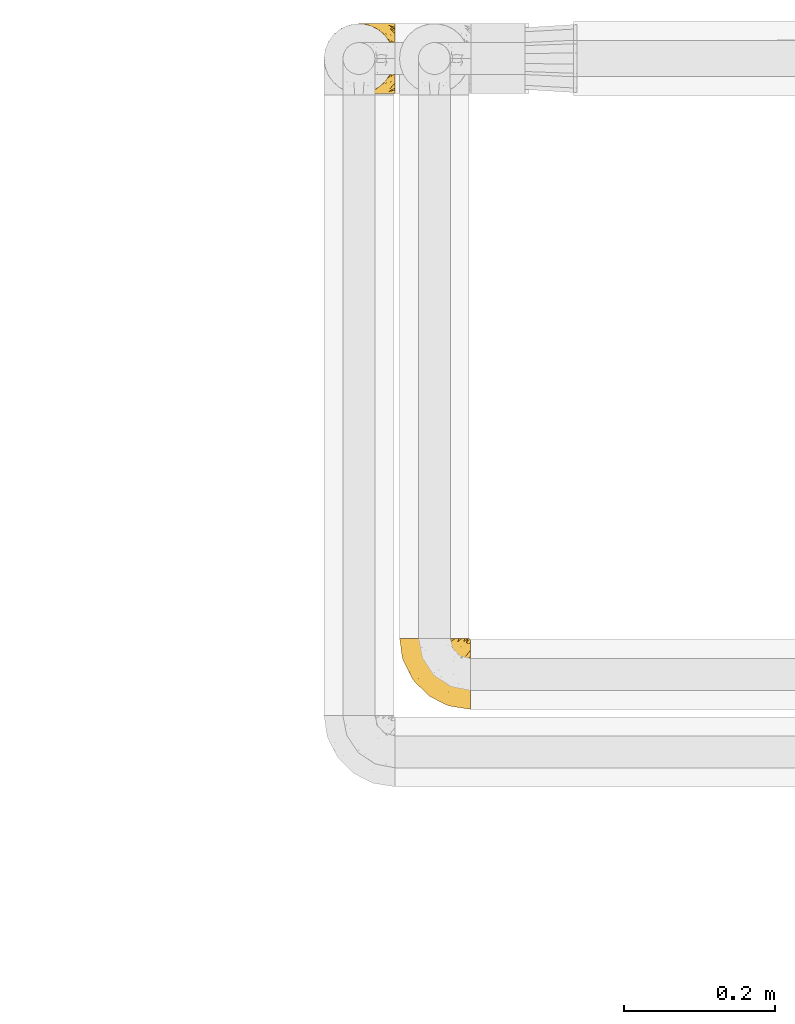
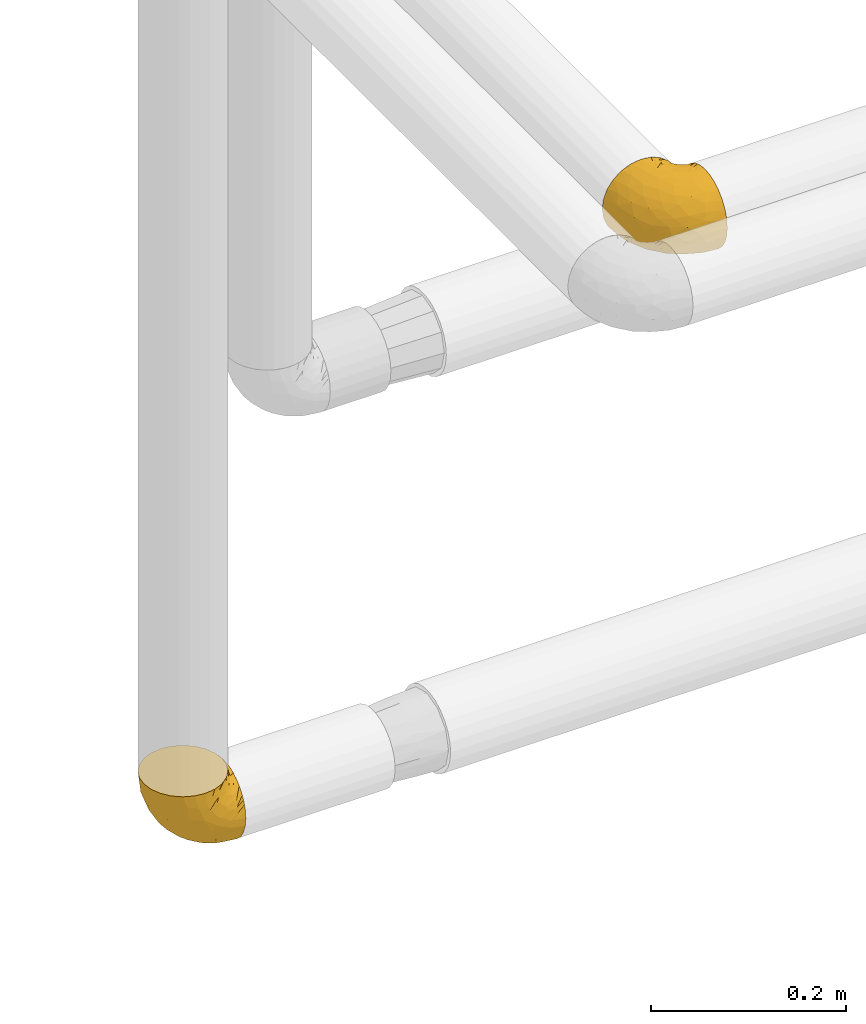
# One storey, part 305 of 827: 2 coverings.
"""IFC2X3 building model written with IfcOpenShell, lengths in millimetres."""

from ifc_helpers import new_model, entity, si_unit, converted_unit, derived_unit, direction, frame, origin, place, context, subcontext, project, spatial, faceted_brep, element, save


model = new_model("IFC2X3")

# Units and contexts
model_context = context("Model", 3, precision=0.01, world=origin(), true_north=direction((6.12303176911189e-17, 1.0)))
body_context = subcontext(model_context, "Body", "Model", "MODEL_VIEW")
ifc_project = project(units=[si_unit("LENGTHUNIT", "METRE", prefix="MILLI"), si_unit("AREAUNIT", "SQUARE_METRE"), si_unit("VOLUMEUNIT", "CUBIC_METRE"), converted_unit("PLANEANGLEUNIT", "DEGREE", entity("IfcRatioMeasure", 0.0174532925199433), si_unit("PLANEANGLEUNIT", "RADIAN"), dimensions=[0, 0, 0, 0, 0, 0, 0]), si_unit("MASSUNIT", "GRAM", prefix="KILO"), derived_unit("MASSDENSITYUNIT", [(si_unit("MASSUNIT", "GRAM", prefix="KILO"), 1), (si_unit("LENGTHUNIT", "METRE"), -3)]), derived_unit("MOMENTOFINERTIAUNIT", [(si_unit("LENGTHUNIT", "METRE"), 4)]), si_unit("TIMEUNIT", "SECOND"), si_unit("FREQUENCYUNIT", "HERTZ"), si_unit("THERMODYNAMICTEMPERATUREUNIT", "DEGREE_CELSIUS"), derived_unit("THERMALTRANSMITTANCEUNIT", [(si_unit("MASSUNIT", "GRAM", prefix="KILO"), 1), (si_unit("THERMODYNAMICTEMPERATUREUNIT", "KELVIN"), -1), (si_unit("TIMEUNIT", "SECOND"), -3)]), derived_unit("VOLUMETRICFLOWRATEUNIT", [(si_unit("LENGTHUNIT", "METRE"), 3), (si_unit("TIMEUNIT", "SECOND"), -1)]), derived_unit("MASSFLOWRATEUNIT", [(si_unit("MASSUNIT", "GRAM", prefix="KILO"), 1), (si_unit("TIMEUNIT", "SECOND"), -1)]), derived_unit("ROTATIONALFREQUENCYUNIT", [(si_unit("TIMEUNIT", "SECOND"), -1)]), si_unit("ELECTRICCURRENTUNIT", "AMPERE"), si_unit("ELECTRICVOLTAGEUNIT", "VOLT"), si_unit("POWERUNIT", "WATT"), si_unit("FORCEUNIT", "NEWTON", prefix="KILO"), si_unit("ILLUMINANCEUNIT", "LUX"), si_unit("LUMINOUSFLUXUNIT", "LUMEN"), si_unit("LUMINOUSINTENSITYUNIT", "CANDELA"), derived_unit("USERDEFINED", [(si_unit("MASSUNIT", "GRAM", prefix="KILO"), -1), (si_unit("LENGTHUNIT", "METRE"), -2), (si_unit("TIMEUNIT", "SECOND"), 3), (si_unit("LUMINOUSFLUXUNIT", "LUMEN"), 1)]), derived_unit("LINEARVELOCITYUNIT", [(si_unit("LENGTHUNIT", "METRE"), 1), (si_unit("TIMEUNIT", "SECOND"), -1)]), si_unit("PRESSUREUNIT", "PASCAL"), derived_unit("USERDEFINED", [(si_unit("LENGTHUNIT", "METRE"), -2), (si_unit("MASSUNIT", "GRAM", prefix="KILO"), 1), (si_unit("TIMEUNIT", "SECOND"), -2)]), derived_unit("LINEARFORCEUNIT", [(si_unit("MASSUNIT", "GRAM", prefix="KILO"), 1), (si_unit("LENGTHUNIT", "METRE"), 1), (si_unit("TIMEUNIT", "SECOND"), -2), (si_unit("LENGTHUNIT", "METRE"), -1)]), derived_unit("PLANARFORCEUNIT", [(si_unit("MASSUNIT", "GRAM", prefix="KILO"), 1), (si_unit("LENGTHUNIT", "METRE"), 1), (si_unit("TIMEUNIT", "SECOND"), -2), (si_unit("LENGTHUNIT", "METRE"), -2)])], contexts=[model_context])

# Site, building, storey
site_placement = place(None, origin())
site = spatial("IfcSite", under=ifc_project, at=site_placement, CompositionType="ELEMENT")
building_placement = place(site_placement, origin())
building = spatial("IfcBuilding", under=site, at=building_placement, CompositionType="ELEMENT")
storey_placement = place(building_placement, frame((0.0, 0.0, 28200.0)))
storey = spatial("IfcBuildingStorey", under=building, at=storey_placement, Name="08", CompositionType="ELEMENT", Elevation=28200.0)

# Coverings
covering_1_placement = place(storey_placement, frame((28192.24, 19468.41, 1752.2)))
element("IfcCovering", 1, at=covering_1_placement, inside=storey, Name=":ADSK_", ObjectType=":ADSK_", PredefinedType="INSULATION", context=body_context, shape_type="Brep", body=[
    faceted_brep([(95.8, 11.68, 18.98), (95.8, 19.0, 11.67), (95.8, 27.76, 6.17), (95.8, 37.52, 2.75), (95.8, 47.8, 1.6), (95.8, 58.08, 2.75), (95.8, 67.85, 6.17), (95.8, 76.61, 11.68), (95.8, 83.92, 19.0), (95.8, 89.42, 27.76), (95.8, 92.84, 37.52), (95.8, 94.0, 47.8), (95.8, 93.53, 51.94), (95.8, 93.18, 55.01), (95.8, 92.84, 58.08), (95.8, 91.13, 62.96), (95.8, 89.42, 67.85), (95.8, 86.66, 72.23), (95.8, 83.91, 76.61), (95.8, 80.25, 80.26), (95.8, 76.59, 83.92), (95.8, 67.83, 89.42), (95.8, 62.95, 91.13), (95.8, 58.07, 92.84), (95.8, 47.8, 94.0), (95.8, 37.51, 92.84), (95.8, 32.63, 91.13), (95.8, 27.74, 89.42), (95.8, 18.98, 83.91), (95.8, 15.33, 80.25), (95.8, 11.67, 76.59), (95.8, 8.92, 72.21), (95.8, 6.17, 67.83), (95.8, 4.46, 62.95), (95.8, 2.75, 58.07), (95.8, 2.41, 55.0), (95.8, 2.06, 51.94), (95.8, 1.6, 47.8), (95.8, 2.75, 37.51), (95.8, 6.17, 27.74), (94.0, 47.8, 95.8), (92.42, 59.75, 95.8), (87.81, 70.9, 95.8), (84.13, 75.68, 95.8), (80.46, 80.46, 95.8), (75.68, 84.13, 95.8), (70.9, 87.81, 95.8), (65.32, 90.11, 95.8), (59.75, 92.42, 95.8), (56.14, 92.9, 95.8), (54.06, 93.17, 95.8), (51.97, 93.45, 95.8), (47.8, 94.0, 95.8), (35.84, 92.42, 95.8), (24.7, 87.81, 95.8), (15.13, 80.46, 95.8), (7.78, 70.9, 95.8), (3.17, 59.75, 95.8), (1.6, 47.8, 95.8), (3.17, 35.84, 95.8), (7.78, 24.7, 95.8), (15.13, 15.13, 95.8), (24.7, 7.78, 95.8), (35.84, 3.17, 95.8), (47.8, 1.6, 95.8), (51.97, 2.14, 95.8), (56.14, 2.69, 95.8), (59.75, 3.17, 95.8), (65.32, 5.48, 95.8), (70.9, 7.78, 95.8), (75.68, 11.46, 95.8), (80.46, 15.13, 95.8), (84.13, 19.91, 95.8), (87.81, 24.7, 95.8), (92.42, 35.84, 95.8), (15.84, 23.61, 60.58), (6.99, 31.99, 74.11), (14.39, 35.87, 51.59), (6.21, 47.8, 66.69), (4.26, 40.43, 76.19), (3.39, 47.8, 84.43), (31.2, 31.83, 31.2), (26.47, 23.37, 42.88), (11.44, 21.41, 79.41), (47.66, 3.07, 60.7), (61.85, 1.6, 61.85), (59.25, 1.6, 65.75), (56.65, 1.6, 69.64), (54.05, 1.6, 73.53), (51.45, 1.6, 77.43), (19.8, 13.45, 74.59), (26.22, 15.25, 54.72), (31.58, 8.07, 64.18), (38.36, 16.0, 37.94), (51.54, 17.34, 25.89), (51.6, 10.58, 34.73), (55.97, 5.34, 42.89), (62.88, 2.39, 49.83), (41.35, 8.36, 48.58), (82.24, 10.04, 22.41), (40.88, 2.59, 78.69), (29.0, 6.28, 81.64), (74.06, 34.28, 6.22), (54.53, 38.73, 12.11), (57.98, 27.25, 14.81), (43.81, 29.88, 21.61), (38.22, 38.6, 22.41), (38.33, 23.44, 30.12), (74.76, 25.25, 10.01), (76.85, 17.23, 15.36), (84.43, 47.8, 3.39), (40.43, 47.8, 19.59), (30.01, 47.8, 30.01), (78.67, 2.53, 41.19), (92.06, 1.6, 48.54), (88.32, 1.6, 49.28), (85.6, 1.6, 49.82), (82.88, 1.6, 50.37), (80.15, 1.6, 50.91), (77.43, 1.6, 51.45), (76.36, 5.71, 31.61), (50.91, 1.6, 80.15), (50.37, 1.6, 82.88), (49.82, 1.6, 85.6), (49.28, 1.6, 88.32), (48.91, 1.6, 90.19), (48.54, 1.6, 92.06), (66.69, 47.8, 6.21), (73.53, 1.6, 54.05), (69.64, 1.6, 56.65), (65.75, 1.6, 59.25), (66.13, 11.89, 24.66), (19.59, 47.8, 40.43), (24.64, 39.69, 35.17), (53.56, 47.8, 12.9), (12.9, 47.8, 53.56), (82.81, 13.84, 85.34), (81.22, 9.16, 78.44), (86.57, 15.79, 84.37), (92.75, 25.75, 89.05), (89.68, 16.09, 82.76), (72.26, 7.51, 86.31), (64.73, 3.99, 83.73), (62.45, 2.66, 77.31), (60.63, 3.16, 87.78), (56.91, 2.35, 87.91), (58.14, 2.23, 81.29), (93.7, 38.35, 93.97), (83.4, 6.18, 70.76), (75.54, 2.7, 63.67), (79.46, 2.93, 62.62), (82.28, 16.01, 90.64), (76.25, 9.08, 84.08), (90.18, 11.68, 77.45), (87.92, 6.83, 70.34), (86.94, 21.65, 91.35), (65.12, 4.65, 88.72), (71.71, 3.65, 71.28), (75.21, 3.61, 68.09), (78.6, 12.8, 91.07), (87.27, 2.43, 57.47), (86.1, 3.7, 62.99), (94.52, 47.8, 94.52), (66.23, 3.37, 76.47), (84.69, 9.3, 76.28), (91.08, 7.03, 69.96), (71.77, 7.87, 89.86), (76.21, 7.26, 78.94), (68.59, 3.41, 73.51), (89.94, 23.81, 89.62), (76.22, 88.32, 78.96), (81.22, 86.42, 78.46), (71.7, 91.93, 71.31), (49.28, 94.0, 88.32), (48.54, 94.0, 92.06), (50.37, 94.0, 82.88), (49.82, 94.0, 85.6), (93.7, 57.24, 93.97), (89.95, 71.76, 89.63), (82.88, 94.0, 50.37), (85.6, 94.0, 49.82), (92.06, 94.0, 48.54), (88.32, 94.0, 49.28), (89.68, 79.49, 82.77), (87.92, 88.75, 70.36), (62.45, 92.93, 77.31), (66.24, 92.22, 76.47), (56.65, 94.0, 69.64), (59.25, 94.0, 65.75), (78.6, 82.79, 91.06), (60.63, 92.43, 87.78), (56.91, 93.24, 87.91), (92.76, 69.82, 89.06), (76.25, 86.5, 84.09), (82.28, 79.57, 90.65), (82.81, 81.74, 85.35), (54.05, 94.0, 73.53), (51.45, 94.0, 77.43), (58.14, 93.36, 81.29), (90.18, 83.9, 77.46), (84.7, 86.28, 76.29), (87.25, 93.16, 57.47), (75.58, 92.88, 63.71), (75.2, 91.98, 68.11), (83.39, 89.41, 70.77), (90.73, 88.82, 69.52), (79.47, 92.66, 62.64), (86.94, 73.93, 91.35), (65.75, 94.0, 59.25), (86.75, 79.5, 84.6), (86.08, 91.89, 62.98), (77.43, 94.0, 51.45), (73.53, 94.0, 54.05), (69.64, 94.0, 56.65), (64.73, 91.6, 83.73), (50.91, 94.0, 80.15), (65.12, 90.94, 88.72), (72.26, 88.08, 86.3), (61.85, 94.0, 61.85), (68.62, 92.16, 73.56), (74.03, 86.13, 91.36), (80.15, 94.0, 50.91), (49.81, 93.2, 62.87), (4.26, 55.16, 76.19), (19.95, 82.02, 73.57), (30.61, 84.29, 56.07), (25.71, 76.94, 49.77), (22.43, 68.33, 44.73), (15.85, 71.98, 60.58), (60.69, 92.52, 47.64), (40.49, 92.9, 78.32), (14.39, 59.72, 51.59), (6.99, 63.6, 74.11), (29.56, 88.89, 76.04), (11.45, 74.18, 79.41), (57.98, 68.35, 14.82), (74.06, 61.33, 6.22), (54.52, 56.86, 12.12), (43.47, 68.62, 23.51), (31.2, 63.76, 31.2), (33.27, 72.19, 34.96), (64.26, 88.69, 33.86), (74.29, 92.19, 38.94), (80.41, 89.75, 30.23), (24.64, 55.9, 35.17), (73.62, 77.99, 15.85), (78.98, 85.21, 22.59), (53.69, 74.99, 21.56), (42.86, 90.23, 55.94), (41.67, 59.86, 20.67), (79.66, 70.75, 9.19), (58.41, 81.72, 25.79), (47.11, 86.53, 41.16), (38.37, 79.6, 37.95)], [[[0, 1, 2, 3, 4, 5, 6, 7, 8, 9, 10, 11, 12, 13, 14, 15, 16, 17, 18, 19, 20, 21, 22, 23, 24, 25, 26, 27, 28, 29, 30, 31, 32, 33, 34, 35, 36, 37, 38, 39]], [[40, 41, 42, 43, 44, 45, 46, 47, 48, 49, 50, 51, 52, 53, 54, 55, 56, 57, 58, 59, 60, 61, 62, 63, 64, 65, 66, 67, 68, 69, 70, 71, 72, 73, 74]], [[75, 76, 77]], [[78, 79, 80]], [[77, 81, 82]], [[76, 75, 83]], [[84, 85, 86, 87, 88, 89]], [[90, 91, 92]], [[76, 60, 59]], [[93, 94, 95]], [[90, 62, 61]], [[83, 61, 60]], [[96, 97, 84]], [[98, 93, 95]], [[0, 39, 99]], [[100, 84, 89]], [[62, 101, 63]], [[2, 102, 3]], [[92, 84, 100]], [[103, 102, 104]], [[103, 105, 106]], [[93, 107, 94]], [[1, 108, 2]], [[92, 101, 90]], [[108, 1, 109]], [[102, 110, 3]], [[93, 82, 107]], [[102, 108, 104]], [[111, 106, 112]], [[109, 0, 99]], [[113, 37, 114, 115, 116, 117, 118, 119]], [[120, 38, 113]], [[100, 89, 121, 122, 123, 124, 125, 126, 64]], [[127, 102, 103]], [[97, 119, 128, 129, 130, 85]], [[99, 120, 131]], [[132, 133, 77]], [[59, 80, 79]], [[1, 0, 109]], [[98, 84, 92]], [[94, 109, 131]], [[120, 39, 38]], [[93, 91, 82]], [[104, 94, 105]], [[97, 113, 119]], [[95, 120, 96]], [[83, 90, 61]], [[91, 93, 98]], [[64, 63, 100]], [[100, 63, 101]], [[77, 76, 79]], [[133, 106, 81]], [[84, 97, 85]], [[113, 96, 120]], [[113, 97, 96]], [[37, 113, 38]], [[110, 102, 127]], [[110, 4, 3]], [[103, 111, 134, 127]], [[90, 75, 91]], [[82, 81, 107]], [[91, 75, 82]], [[77, 82, 75]], [[76, 83, 60]], [[90, 83, 75]], [[105, 107, 81]], [[94, 131, 95]], [[105, 94, 107]], [[109, 94, 104]], [[120, 95, 131]], [[98, 95, 96]], [[84, 98, 96]], [[98, 92, 91]], [[106, 105, 81]], [[103, 104, 105]], [[133, 132, 112]], [[103, 106, 111]], [[77, 78, 135, 132]], [[106, 133, 112]], [[77, 133, 81]], [[120, 99, 39]], [[109, 99, 131]], [[59, 58, 80]], [[59, 79, 76]], [[90, 101, 62]], [[100, 101, 92]], [[2, 108, 102]], [[109, 104, 108]], [[78, 77, 79]], [[136, 137, 138]], [[27, 139, 140]], [[141, 142, 143]], [[144, 145, 121]], [[146, 89, 88]], [[147, 139, 25]], [[148, 149, 150]], [[136, 151, 152]], [[147, 40, 74]], [[24, 147, 25]], [[153, 148, 154]], [[33, 116, 34]], [[73, 151, 155]], [[114, 37, 36, 35, 34, 116, 115]], [[146, 156, 144]], [[157, 85, 130]], [[158, 149, 148]], [[151, 159, 152]], [[117, 33, 160]], [[29, 153, 154]], [[155, 74, 73]], [[161, 128, 119]], [[65, 64, 126, 125, 124, 123, 122, 67, 66]], [[162, 147, 24]], [[27, 140, 28]], [[149, 129, 150]], [[139, 27, 26, 25]], [[68, 144, 69]], [[129, 128, 150]], [[163, 87, 86]], [[130, 129, 149]], [[122, 145, 67]], [[153, 164, 148]], [[161, 119, 160]], [[165, 30, 154]], [[150, 154, 148]], [[128, 161, 150]], [[30, 165, 31]], [[145, 144, 68]], [[89, 146, 144]], [[87, 163, 143]], [[166, 156, 142]], [[88, 87, 143]], [[161, 154, 150]], [[154, 30, 29]], [[29, 28, 153]], [[28, 140, 153]], [[164, 153, 140]], [[140, 137, 164]], [[158, 148, 164]], [[157, 130, 158]], [[164, 137, 158]], [[158, 137, 157]], [[167, 137, 136]], [[168, 85, 157]], [[152, 168, 167]], [[167, 168, 157]], [[163, 152, 141]], [[151, 73, 72]], [[159, 72, 71]], [[88, 142, 146]], [[144, 156, 69]], [[146, 142, 156]], [[70, 166, 71]], [[142, 141, 166]], [[70, 69, 156]], [[141, 159, 71]], [[167, 136, 152]], [[138, 137, 140]], [[155, 136, 169]], [[136, 155, 151]], [[74, 155, 169]], [[152, 159, 141]], [[151, 72, 159]], [[168, 152, 163]], [[137, 167, 157]], [[163, 86, 168]], [[85, 168, 86]], [[116, 33, 117]], [[130, 149, 158]], [[67, 145, 68]], [[121, 89, 144]], [[145, 122, 121]], [[40, 147, 162]], [[169, 147, 74]], [[160, 33, 32]], [[161, 160, 32]], [[160, 119, 118, 117]], [[139, 147, 169]], [[139, 169, 138]], [[161, 32, 31]], [[141, 143, 163]], [[88, 143, 142]], [[71, 166, 141]], [[156, 166, 70]], [[139, 138, 140]], [[169, 136, 138]], [[154, 161, 165]], [[161, 31, 165]], [[170, 171, 172]], [[173, 174, 52, 51, 50, 49, 48, 175, 176]], [[177, 178, 41]], [[179, 15, 180]], [[12, 11, 181, 182, 180, 14, 13]], [[183, 21, 20]], [[19, 18, 184]], [[185, 186, 187]], [[186, 188, 187]], [[43, 189, 44]], [[190, 191, 47]], [[23, 22, 21, 192]], [[193, 194, 195]], [[40, 162, 177]], [[196, 197, 198]], [[24, 23, 177]], [[199, 200, 183]], [[201, 15, 179]], [[47, 46, 190]], [[202, 203, 204]], [[203, 172, 171]], [[205, 206, 184]], [[207, 41, 178]], [[16, 15, 201]], [[14, 180, 15]], [[204, 203, 200]], [[208, 203, 202]], [[162, 24, 177]], [[48, 47, 191]], [[198, 197, 190]], [[199, 184, 204]], [[171, 195, 209]], [[210, 211, 212]], [[206, 212, 213]], [[205, 17, 210]], [[184, 206, 204]], [[210, 212, 206]], [[185, 196, 214]], [[190, 215, 191]], [[216, 45, 214]], [[186, 217, 193]], [[190, 216, 198]], [[199, 20, 19]], [[196, 185, 187]], [[199, 183, 20]], [[184, 199, 19]], [[199, 204, 200]], [[206, 202, 204]], [[171, 183, 200]], [[203, 208, 172]], [[172, 208, 218]], [[171, 200, 203]], [[218, 188, 219]], [[195, 170, 193]], [[217, 186, 185]], [[193, 219, 186]], [[193, 170, 219]], [[207, 194, 42]], [[217, 220, 189]], [[216, 190, 46]], [[214, 196, 198]], [[44, 220, 45]], [[214, 198, 216]], [[216, 46, 45]], [[214, 45, 220]], [[42, 194, 43]], [[189, 193, 217]], [[207, 195, 194]], [[209, 195, 178]], [[41, 207, 42]], [[195, 207, 178]], [[43, 194, 189]], [[193, 189, 194]], [[171, 170, 195]], [[170, 172, 219]], [[218, 219, 172]], [[188, 186, 219]], [[206, 213, 202]], [[208, 202, 213]], [[201, 210, 16]], [[215, 190, 197]], [[215, 175, 191]], [[175, 48, 191]], [[201, 179, 221, 211]], [[210, 201, 211]], [[23, 192, 177]], [[40, 177, 41]], [[183, 209, 192]], [[183, 192, 21]], [[192, 178, 177]], [[205, 18, 17]], [[17, 16, 210]], [[217, 185, 214]], [[189, 220, 44]], [[214, 220, 217]], [[192, 209, 178]], [[171, 209, 183]], [[206, 205, 210]], [[18, 205, 184]], [[222, 197, 196, 187, 188, 218]], [[57, 223, 80]], [[224, 225, 226]], [[226, 227, 228]], [[229, 218, 208, 213, 212, 211]], [[230, 52, 174, 173, 176, 175, 215, 197]], [[231, 232, 228]], [[231, 78, 223]], [[223, 57, 232]], [[224, 233, 225]], [[233, 54, 53]], [[234, 232, 56]], [[56, 55, 234]], [[234, 224, 228]], [[235, 236, 237]], [[224, 55, 54]], [[238, 239, 240]], [[52, 230, 53]], [[241, 242, 243]], [[227, 244, 231]], [[11, 10, 242]], [[236, 6, 5]], [[7, 245, 8]], [[8, 246, 9]], [[238, 247, 235]], [[222, 229, 248]], [[242, 211, 221, 179, 180, 182, 181, 11]], [[233, 53, 230]], [[111, 112, 249]], [[250, 6, 236]], [[246, 251, 241]], [[6, 250, 7]], [[127, 236, 110]], [[248, 229, 252]], [[246, 8, 245]], [[235, 245, 250]], [[236, 5, 110]], [[235, 249, 238]], [[237, 236, 127]], [[243, 9, 246]], [[252, 229, 241]], [[56, 232, 57]], [[222, 230, 197]], [[225, 248, 252]], [[248, 233, 230]], [[54, 233, 224]], [[231, 228, 227]], [[244, 132, 231]], [[248, 225, 233]], [[226, 225, 253]], [[235, 250, 236]], [[245, 7, 250]], [[251, 246, 245]], [[243, 246, 241]], [[247, 245, 235]], [[252, 251, 253]], [[229, 222, 218]], [[230, 222, 248]], [[5, 4, 110]], [[237, 127, 134, 111]], [[238, 249, 239]], [[224, 234, 55]], [[232, 234, 228]], [[242, 241, 229]], [[10, 9, 243]], [[211, 242, 229]], [[10, 243, 242]], [[80, 223, 78]], [[80, 58, 57]], [[231, 223, 232]], [[227, 240, 239]], [[224, 226, 228]], [[240, 226, 253]], [[227, 239, 244]], [[226, 240, 227]], [[251, 247, 253]], [[240, 253, 247]], [[249, 235, 237]], [[237, 111, 249]], [[112, 132, 244]], [[112, 244, 249]], [[78, 231, 132, 135]], [[249, 244, 239]], [[247, 238, 240]], [[245, 247, 251]], [[251, 252, 241]], [[225, 252, 253]]]),
])
covering_2_placement = place(storey_placement, frame((28292.23, 18652.21, 2952.11)))
element("IfcCovering", 2, at=covering_2_placement, inside=storey, Name=":ADSK_", ObjectType=":ADSK_", PredefinedType="INSULATION", context=body_context, shape_type="Brep", body=[
    faceted_brep([(95.8, 37.51, 92.84), (95.8, 27.74, 89.42), (95.8, 18.98, 83.91), (95.8, 11.67, 76.59), (95.8, 6.17, 67.83), (95.8, 2.75, 58.07), (95.8, 1.6, 47.8), (95.8, 2.75, 37.51), (95.8, 6.17, 27.74), (95.8, 11.68, 18.98), (95.8, 19.0, 11.67), (95.8, 27.76, 6.17), (95.8, 37.52, 2.75), (95.8, 47.8, 1.6), (95.8, 51.94, 2.06), (95.8, 55.01, 2.41), (95.8, 58.08, 2.75), (95.8, 62.96, 4.46), (95.8, 67.85, 6.17), (95.8, 72.23, 8.93), (95.8, 76.61, 11.68), (95.8, 80.26, 15.34), (95.8, 83.92, 19.0), (95.8, 89.42, 27.76), (95.8, 91.13, 32.64), (95.8, 92.84, 37.52), (95.8, 94.0, 47.8), (95.8, 92.84, 58.08), (95.8, 91.13, 62.96), (95.8, 89.42, 67.85), (95.8, 83.91, 76.61), (95.8, 80.25, 80.26), (95.8, 76.59, 83.92), (95.8, 72.21, 86.67), (95.8, 67.83, 89.42), (95.8, 62.95, 91.13), (95.8, 58.07, 92.84), (95.8, 55.0, 93.18), (95.8, 51.94, 93.53), (95.8, 47.8, 94.0), (94.0, 95.8, 47.8), (92.42, 95.8, 35.84), (87.81, 95.8, 24.7), (84.13, 95.8, 19.91), (80.46, 95.8, 15.13), (75.68, 95.8, 11.46), (70.9, 95.8, 7.78), (65.32, 95.8, 5.48), (59.75, 95.8, 3.17), (56.14, 95.8, 2.69), (54.06, 95.8, 2.42), (51.97, 95.8, 2.14), (47.8, 95.8, 1.6), (35.84, 95.8, 3.17), (24.7, 95.8, 7.78), (15.13, 95.8, 15.13), (7.78, 95.8, 24.7), (3.17, 95.8, 35.84), (1.6, 95.8, 47.8), (3.17, 95.8, 59.75), (7.78, 95.8, 70.9), (15.13, 95.8, 80.46), (24.7, 95.8, 87.81), (35.84, 95.8, 92.42), (47.8, 95.8, 94.0), (51.97, 95.8, 93.45), (56.14, 95.8, 92.9), (59.75, 95.8, 92.42), (65.32, 95.8, 90.11), (70.9, 95.8, 87.81), (75.68, 95.8, 84.13), (80.46, 95.8, 80.46), (84.13, 95.8, 75.68), (87.81, 95.8, 70.9), (92.42, 95.8, 59.75), (15.84, 60.58, 71.98), (6.99, 74.11, 63.6), (14.39, 51.59, 59.72), (6.21, 66.69, 47.8), (4.26, 76.19, 55.16), (3.39, 84.43, 47.8), (31.2, 31.2, 63.76), (26.47, 42.88, 72.22), (11.44, 79.41, 74.18), (47.66, 60.7, 92.52), (61.85, 61.85, 94.0), (59.25, 65.75, 94.0), (56.65, 69.64, 94.0), (54.05, 73.53, 94.0), (51.45, 77.43, 94.0), (19.8, 74.59, 82.14), (26.22, 54.72, 80.34), (31.58, 64.18, 87.52), (38.36, 37.94, 79.59), (51.54, 25.89, 78.25), (51.6, 34.73, 85.01), (55.97, 42.89, 90.25), (62.88, 49.83, 93.2), (41.35, 48.58, 87.23), (82.24, 22.41, 85.55), (40.88, 78.69, 93.0), (29.0, 81.64, 89.31), (74.06, 6.22, 61.31), (54.53, 12.11, 56.86), (57.98, 14.81, 68.34), (43.81, 21.61, 65.71), (38.22, 22.41, 56.99), (38.33, 30.12, 72.15), (74.76, 10.01, 70.34), (76.85, 15.36, 78.36), (84.43, 3.39, 47.8), (40.43, 19.59, 47.8), (30.01, 30.01, 47.8), (78.67, 41.19, 93.06), (92.06, 48.54, 94.0), (88.32, 49.28, 94.0), (85.6, 49.82, 94.0), (82.88, 50.37, 94.0), (80.15, 50.91, 94.0), (77.43, 51.45, 94.0), (76.36, 31.61, 89.88), (50.91, 80.15, 94.0), (50.37, 82.88, 94.0), (49.82, 85.6, 94.0), (49.28, 88.32, 94.0), (48.91, 90.19, 94.0), (48.54, 92.06, 94.0), (66.69, 6.21, 47.8), (73.53, 54.05, 94.0), (69.64, 56.65, 94.0), (65.75, 59.25, 94.0), (66.13, 24.66, 83.7), (19.59, 40.43, 47.8), (24.64, 35.17, 55.9), (53.56, 12.9, 47.8), (12.9, 53.56, 47.8), (82.81, 85.34, 81.75), (81.22, 78.44, 86.43), (86.57, 84.37, 79.8), (92.75, 89.05, 69.84), (89.68, 82.76, 79.5), (72.26, 86.31, 88.08), (64.73, 83.73, 91.6), (62.45, 77.31, 92.93), (60.63, 87.78, 92.43), (56.91, 87.91, 93.24), (58.14, 81.29, 93.36), (93.7, 93.97, 57.25), (83.4, 70.76, 89.41), (75.54, 63.67, 92.89), (79.46, 62.62, 92.66), (82.28, 90.64, 79.58), (76.25, 84.08, 86.51), (90.18, 77.45, 83.91), (87.92, 70.34, 88.76), (65.12, 88.72, 90.94), (71.71, 71.28, 91.94), (75.21, 68.09, 91.98), (78.6, 91.07, 82.79), (87.27, 57.47, 93.16), (86.94, 91.35, 73.94), (86.1, 62.99, 91.89), (94.52, 94.52, 47.8), (66.23, 76.47, 92.22), (84.69, 76.28, 86.29), (91.08, 69.96, 88.56), (71.77, 89.86, 87.72), (76.21, 78.94, 88.33), (68.59, 73.51, 92.18), (89.94, 89.62, 71.78), (76.22, 78.96, 7.27), (81.22, 78.46, 9.17), (71.7, 71.31, 3.66), (49.28, 88.32, 1.6), (48.54, 92.06, 1.6), (50.37, 82.88, 1.6), (49.82, 85.6, 1.6), (93.7, 93.97, 38.35), (89.95, 89.63, 23.84), (82.88, 50.37, 1.6), (85.6, 49.82, 1.6), (92.06, 48.54, 1.6), (88.32, 49.28, 1.6), (89.68, 82.77, 16.1), (87.92, 70.36, 6.84), (62.45, 77.31, 2.66), (66.24, 76.47, 3.37), (56.65, 69.64, 1.6), (59.25, 65.75, 1.6), (78.6, 91.06, 12.8), (60.63, 87.78, 3.16), (56.91, 87.91, 2.35), (92.76, 89.06, 25.77), (76.25, 84.09, 9.09), (82.28, 90.65, 16.02), (82.81, 85.35, 13.85), (54.05, 73.53, 1.6), (51.45, 77.43, 1.6), (58.14, 81.29, 2.23), (90.18, 77.46, 11.69), (84.7, 76.29, 9.31), (87.25, 57.47, 2.43), (75.58, 63.71, 2.71), (75.2, 68.11, 3.61), (83.39, 70.77, 6.18), (90.73, 69.52, 6.77), (79.47, 62.64, 2.93), (86.94, 91.35, 21.66), (65.75, 59.25, 1.6), (86.75, 84.6, 16.09), (86.08, 62.98, 3.7), (77.43, 51.45, 1.6), (73.53, 54.05, 1.6), (69.64, 56.65, 1.6), (64.73, 83.73, 3.99), (50.91, 80.15, 1.6), (65.12, 88.72, 4.65), (72.26, 86.3, 7.51), (61.85, 61.85, 1.6), (68.62, 73.56, 3.43), (74.03, 91.36, 9.46), (80.15, 50.91, 1.6), (49.81, 62.87, 2.4), (4.26, 76.19, 40.43), (19.95, 73.57, 13.57), (30.61, 56.07, 11.3), (25.71, 49.77, 18.65), (22.43, 44.73, 27.26), (15.85, 60.58, 23.61), (60.69, 47.64, 3.07), (40.49, 78.32, 2.69), (14.39, 51.59, 35.87), (6.99, 74.11, 31.99), (29.56, 76.04, 6.71), (11.45, 79.41, 21.41), (57.98, 14.82, 27.24), (74.06, 6.22, 34.26), (54.52, 12.12, 38.73), (43.47, 23.51, 26.97), (31.2, 31.2, 31.83), (33.27, 34.96, 23.4), (64.26, 33.86, 6.91), (74.29, 38.94, 3.4), (80.41, 30.23, 5.84), (41.67, 20.67, 35.73), (24.64, 35.17, 39.69), (73.62, 15.85, 17.6), (78.98, 22.59, 10.38), (53.69, 21.56, 20.6), (42.86, 55.94, 5.36), (79.66, 9.19, 24.84), (58.41, 25.79, 13.87), (47.11, 41.16, 9.06), (38.37, 37.95, 15.99)], [[[0, 1, 2, 3, 4, 5, 6, 7, 8, 9, 10, 11, 12, 13, 14, 15, 16, 17, 18, 19, 20, 21, 22, 23, 24, 25, 26, 27, 28, 29, 30, 31, 32, 33, 34, 35, 36, 37, 38, 39]], [[40, 41, 42, 43, 44, 45, 46, 47, 48, 49, 50, 51, 52, 53, 54, 55, 56, 57, 58, 59, 60, 61, 62, 63, 64, 65, 66, 67, 68, 69, 70, 71, 72, 73, 74]], [[75, 76, 77]], [[78, 79, 80]], [[77, 81, 82]], [[76, 75, 83]], [[84, 85, 86, 87, 88, 89]], [[90, 91, 92]], [[76, 60, 59]], [[93, 94, 95]], [[90, 62, 61]], [[83, 61, 60]], [[96, 97, 84]], [[98, 93, 95]], [[2, 1, 99]], [[100, 84, 89]], [[62, 101, 63]], [[4, 102, 5]], [[92, 84, 100]], [[103, 102, 104]], [[103, 105, 106]], [[93, 107, 94]], [[3, 108, 4]], [[92, 101, 90]], [[108, 3, 109]], [[102, 110, 5]], [[93, 82, 107]], [[102, 108, 104]], [[111, 106, 112]], [[109, 2, 99]], [[113, 39, 114, 115, 116, 117, 118, 119]], [[120, 0, 113]], [[100, 89, 121, 122, 123, 124, 125, 126, 64]], [[127, 102, 103]], [[97, 119, 128, 129, 130, 85]], [[99, 120, 131]], [[132, 133, 77]], [[59, 80, 79]], [[3, 2, 109]], [[98, 84, 92]], [[94, 109, 131]], [[120, 1, 0]], [[93, 91, 82]], [[104, 94, 105]], [[97, 113, 119]], [[95, 120, 96]], [[83, 90, 61]], [[91, 93, 98]], [[64, 63, 100]], [[100, 63, 101]], [[77, 76, 79]], [[133, 106, 81]], [[84, 97, 85]], [[113, 96, 120]], [[113, 97, 96]], [[39, 113, 0]], [[110, 102, 127]], [[110, 6, 5]], [[103, 111, 134, 127]], [[90, 75, 91]], [[82, 81, 107]], [[91, 75, 82]], [[77, 82, 75]], [[76, 83, 60]], [[90, 83, 75]], [[105, 107, 81]], [[94, 131, 95]], [[105, 94, 107]], [[109, 94, 104]], [[120, 95, 131]], [[98, 95, 96]], [[84, 98, 96]], [[98, 92, 91]], [[106, 105, 81]], [[103, 104, 105]], [[133, 132, 112]], [[103, 106, 111]], [[77, 78, 135, 132]], [[106, 133, 112]], [[77, 133, 81]], [[120, 99, 1]], [[109, 99, 131]], [[59, 58, 80]], [[59, 79, 76]], [[90, 101, 62]], [[100, 101, 92]], [[4, 108, 102]], [[109, 104, 108]], [[78, 77, 79]], [[136, 137, 138]], [[29, 139, 140]], [[141, 142, 143]], [[144, 145, 121]], [[146, 89, 88]], [[147, 139, 27]], [[148, 149, 150]], [[136, 151, 152]], [[147, 40, 74]], [[26, 147, 27]], [[153, 148, 154]], [[35, 116, 36]], [[73, 72, 151]], [[114, 39, 38, 37, 36, 116, 115]], [[146, 155, 144]], [[156, 85, 130]], [[157, 149, 148]], [[151, 158, 152]], [[117, 35, 159]], [[31, 153, 154]], [[160, 74, 73]], [[161, 128, 119]], [[65, 64, 126, 125, 124, 123, 122, 67, 66]], [[162, 147, 26]], [[29, 140, 30]], [[149, 129, 150]], [[139, 29, 28, 27]], [[68, 144, 69]], [[129, 128, 150]], [[163, 87, 86]], [[130, 129, 149]], [[122, 145, 67]], [[153, 164, 148]], [[161, 119, 159]], [[165, 32, 154]], [[150, 154, 148]], [[128, 161, 150]], [[32, 165, 33]], [[145, 144, 68]], [[89, 146, 144]], [[87, 163, 143]], [[166, 155, 142]], [[88, 87, 143]], [[161, 154, 150]], [[154, 32, 31]], [[31, 30, 153]], [[30, 140, 153]], [[164, 153, 140]], [[140, 137, 164]], [[157, 148, 164]], [[156, 130, 157]], [[164, 137, 157]], [[157, 137, 156]], [[167, 137, 136]], [[168, 85, 156]], [[152, 168, 167]], [[167, 168, 156]], [[163, 152, 141]], [[71, 158, 72]], [[152, 167, 136]], [[88, 142, 146]], [[144, 155, 69]], [[146, 142, 155]], [[70, 166, 71]], [[142, 141, 166]], [[70, 69, 155]], [[141, 158, 71]], [[160, 73, 151]], [[138, 137, 140]], [[160, 136, 169]], [[136, 160, 151]], [[74, 160, 169]], [[152, 158, 141]], [[151, 72, 158]], [[168, 152, 163]], [[137, 167, 156]], [[163, 86, 168]], [[85, 168, 86]], [[116, 35, 117]], [[130, 149, 157]], [[67, 145, 68]], [[121, 89, 144]], [[145, 122, 121]], [[40, 147, 162]], [[169, 147, 74]], [[159, 35, 34]], [[161, 159, 34]], [[159, 119, 118, 117]], [[139, 147, 169]], [[139, 169, 138]], [[161, 34, 33]], [[141, 143, 163]], [[88, 143, 142]], [[71, 166, 141]], [[155, 166, 70]], [[139, 138, 140]], [[169, 136, 138]], [[154, 161, 165]], [[161, 33, 165]], [[170, 171, 172]], [[173, 174, 52, 51, 50, 49, 48, 175, 176]], [[177, 178, 41]], [[179, 17, 180]], [[14, 13, 181, 182, 180, 16, 15]], [[183, 23, 22]], [[21, 20, 184]], [[185, 186, 187]], [[186, 188, 187]], [[43, 189, 44]], [[190, 191, 47]], [[25, 24, 23, 192]], [[193, 194, 195]], [[40, 162, 177]], [[196, 197, 198]], [[26, 25, 177]], [[199, 200, 183]], [[201, 17, 179]], [[178, 177, 192]], [[47, 46, 190]], [[202, 203, 204]], [[203, 172, 171]], [[205, 206, 184]], [[207, 41, 178]], [[18, 17, 201]], [[16, 180, 17]], [[204, 203, 200]], [[208, 203, 202]], [[162, 26, 177]], [[48, 47, 191]], [[198, 197, 190]], [[199, 184, 204]], [[171, 195, 209]], [[210, 211, 212]], [[206, 212, 213]], [[205, 19, 210]], [[184, 206, 204]], [[210, 212, 206]], [[185, 196, 214]], [[190, 215, 191]], [[216, 45, 214]], [[186, 217, 193]], [[190, 216, 198]], [[199, 22, 21]], [[196, 185, 187]], [[199, 183, 22]], [[184, 199, 21]], [[199, 204, 200]], [[206, 202, 204]], [[171, 183, 200]], [[203, 208, 172]], [[172, 208, 218]], [[171, 200, 203]], [[218, 188, 219]], [[195, 170, 193]], [[217, 186, 185]], [[193, 219, 186]], [[193, 170, 219]], [[207, 194, 42]], [[217, 220, 189]], [[216, 190, 46]], [[214, 196, 198]], [[44, 220, 45]], [[214, 198, 216]], [[216, 46, 45]], [[214, 45, 220]], [[42, 194, 43]], [[189, 193, 217]], [[207, 195, 194]], [[209, 195, 178]], [[41, 207, 42]], [[195, 207, 178]], [[43, 194, 189]], [[193, 189, 194]], [[171, 170, 195]], [[170, 172, 219]], [[218, 219, 172]], [[188, 186, 219]], [[206, 213, 202]], [[208, 202, 213]], [[201, 210, 18]], [[215, 190, 197]], [[215, 175, 191]], [[175, 48, 191]], [[201, 179, 221, 211]], [[210, 201, 211]], [[25, 192, 177]], [[40, 177, 41]], [[192, 183, 209]], [[23, 183, 192]], [[205, 20, 19]], [[19, 18, 210]], [[217, 185, 214]], [[189, 220, 44]], [[214, 220, 217]], [[192, 209, 178]], [[171, 209, 183]], [[206, 205, 210]], [[20, 205, 184]], [[222, 197, 196, 187, 188, 218]], [[57, 223, 80]], [[224, 225, 226]], [[226, 227, 228]], [[229, 218, 208, 213, 212, 211]], [[230, 52, 174, 173, 176, 175, 215, 197]], [[231, 232, 228]], [[231, 78, 223]], [[223, 57, 232]], [[224, 233, 225]], [[233, 54, 53]], [[234, 232, 56]], [[56, 55, 234]], [[234, 224, 228]], [[235, 236, 237]], [[224, 55, 54]], [[238, 239, 240]], [[52, 230, 53]], [[241, 242, 243]], [[239, 244, 245]], [[13, 12, 242]], [[236, 8, 7]], [[9, 246, 10]], [[10, 247, 11]], [[238, 248, 235]], [[222, 229, 249]], [[242, 211, 221, 179, 180, 182, 181, 13]], [[233, 53, 230]], [[111, 112, 244]], [[250, 8, 236]], [[247, 251, 241]], [[8, 250, 9]], [[127, 236, 110]], [[249, 229, 252]], [[247, 10, 246]], [[235, 246, 250]], [[236, 7, 110]], [[235, 244, 238]], [[237, 236, 127]], [[243, 11, 247]], [[252, 229, 241]], [[56, 232, 57]], [[222, 230, 197]], [[225, 249, 252]], [[249, 233, 230]], [[54, 233, 224]], [[231, 228, 227]], [[245, 132, 231]], [[249, 225, 233]], [[226, 225, 253]], [[235, 250, 236]], [[246, 9, 250]], [[251, 247, 246]], [[243, 247, 241]], [[248, 246, 235]], [[252, 251, 253]], [[229, 222, 218]], [[230, 222, 249]], [[7, 6, 110]], [[237, 127, 134, 111]], [[238, 244, 239]], [[224, 234, 55]], [[232, 234, 228]], [[242, 241, 229]], [[12, 11, 243]], [[211, 242, 229]], [[12, 243, 242]], [[80, 223, 78]], [[80, 58, 57]], [[231, 223, 232]], [[227, 240, 239]], [[224, 226, 228]], [[240, 226, 253]], [[227, 239, 245]], [[226, 240, 227]], [[251, 248, 253]], [[240, 253, 248]], [[244, 235, 237]], [[237, 111, 244]], [[132, 245, 112]], [[112, 245, 244]], [[135, 78, 231, 132]], [[227, 245, 231]], [[248, 238, 240]], [[246, 248, 251]], [[251, 252, 241]], [[225, 252, 253]]]),
])

save(model, "model.ifc")
